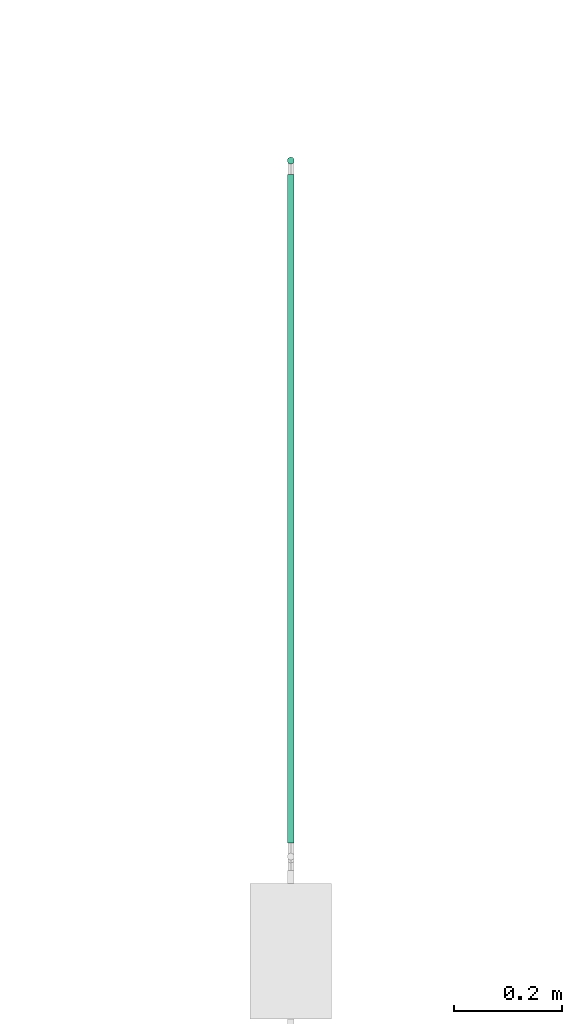
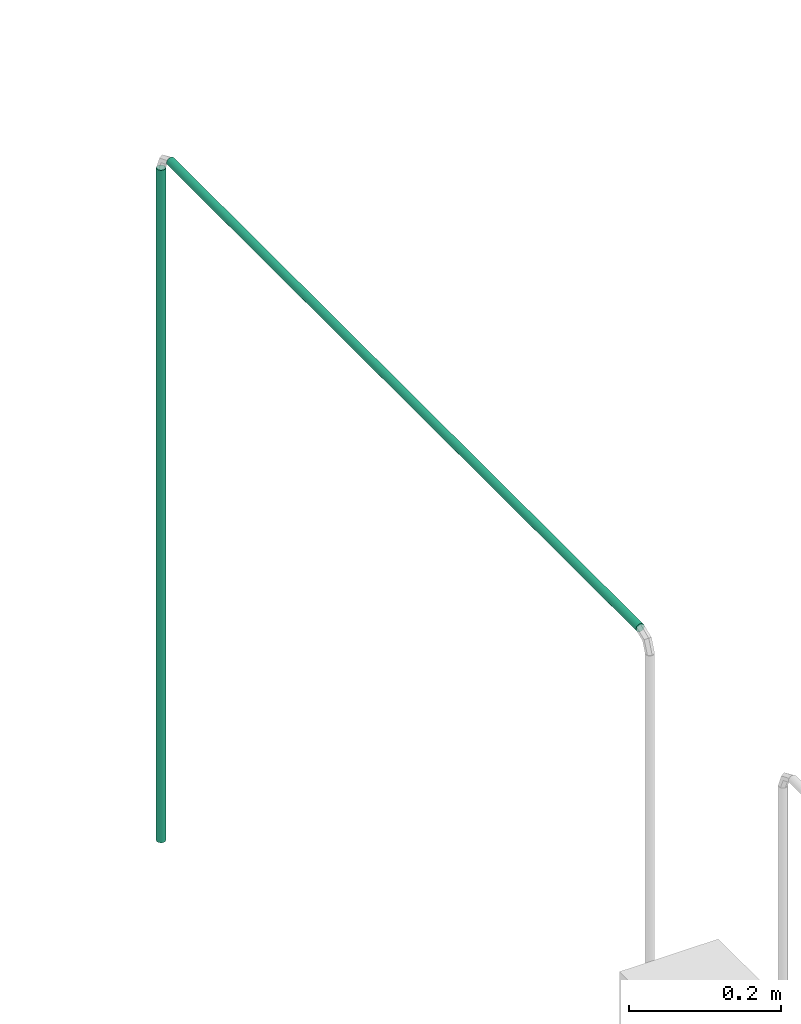
# One storey, part 4 of 45: 2 flow segments.
"""IFC2X3 building model written with IfcOpenShell, lengths in millimetres."""

from ifc_helpers import new_model, entity, si_unit, converted_unit, derived_unit, direction, frame, origin, origin_2d_with_axis, place, context, subcontext, project, spatial, circle, extrude, type_object, element, save


model = new_model("IFC2X3")

# Units and contexts
model_context = context("Model", 3, precision=0.01, world=origin(), true_north=direction((6.12303176911189e-17, 1.0)))
body_context = subcontext(model_context, "Body", "Model", "MODEL_VIEW")
ifc_project = project(units=[si_unit("LENGTHUNIT", "METRE", prefix="MILLI"), si_unit("AREAUNIT", "SQUARE_METRE"), si_unit("VOLUMEUNIT", "CUBIC_METRE"), converted_unit("PLANEANGLEUNIT", "DEGREE", entity("IfcRatioMeasure", 0.0174532925199433), si_unit("PLANEANGLEUNIT", "RADIAN"), dimensions=[0, 0, 0, 0, 0, 0, 0]), si_unit("MASSUNIT", "GRAM", prefix="KILO"), derived_unit("MASSDENSITYUNIT", [(si_unit("MASSUNIT", "GRAM", prefix="KILO"), 1), (si_unit("LENGTHUNIT", "METRE"), -3)]), derived_unit("MOMENTOFINERTIAUNIT", [(si_unit("LENGTHUNIT", "METRE"), 4)]), si_unit("TIMEUNIT", "SECOND"), si_unit("FREQUENCYUNIT", "HERTZ"), si_unit("THERMODYNAMICTEMPERATUREUNIT", "DEGREE_CELSIUS"), derived_unit("THERMALTRANSMITTANCEUNIT", [(si_unit("MASSUNIT", "GRAM", prefix="KILO"), 1), (si_unit("THERMODYNAMICTEMPERATUREUNIT", "KELVIN"), -1), (si_unit("TIMEUNIT", "SECOND"), -3)]), derived_unit("VOLUMETRICFLOWRATEUNIT", [(si_unit("LENGTHUNIT", "METRE"), 3), (si_unit("TIMEUNIT", "SECOND"), -1)]), derived_unit("MASSFLOWRATEUNIT", [(si_unit("MASSUNIT", "GRAM", prefix="KILO"), 1), (si_unit("TIMEUNIT", "SECOND"), -1)]), derived_unit("ROTATIONALFREQUENCYUNIT", [(si_unit("TIMEUNIT", "SECOND"), -1)]), si_unit("ELECTRICCURRENTUNIT", "AMPERE"), si_unit("ELECTRICVOLTAGEUNIT", "VOLT"), si_unit("POWERUNIT", "WATT"), si_unit("FORCEUNIT", "NEWTON", prefix="KILO"), si_unit("ILLUMINANCEUNIT", "LUX"), si_unit("LUMINOUSFLUXUNIT", "LUMEN"), si_unit("LUMINOUSINTENSITYUNIT", "CANDELA"), derived_unit("USERDEFINED", [(si_unit("MASSUNIT", "GRAM", prefix="KILO"), -1), (si_unit("LENGTHUNIT", "METRE"), -2), (si_unit("TIMEUNIT", "SECOND"), 3), (si_unit("LUMINOUSFLUXUNIT", "LUMEN"), 1)]), derived_unit("LINEARVELOCITYUNIT", [(si_unit("LENGTHUNIT", "METRE"), 1), (si_unit("TIMEUNIT", "SECOND"), -1)]), si_unit("PRESSUREUNIT", "PASCAL"), derived_unit("USERDEFINED", [(si_unit("LENGTHUNIT", "METRE"), -2), (si_unit("MASSUNIT", "GRAM", prefix="KILO"), 1), (si_unit("TIMEUNIT", "SECOND"), -2)]), derived_unit("LINEARFORCEUNIT", [(si_unit("MASSUNIT", "GRAM", prefix="KILO"), 1), (si_unit("LENGTHUNIT", "METRE"), 1), (si_unit("TIMEUNIT", "SECOND"), -2), (si_unit("LENGTHUNIT", "METRE"), -1)]), derived_unit("PLANARFORCEUNIT", [(si_unit("MASSUNIT", "GRAM", prefix="KILO"), 1), (si_unit("LENGTHUNIT", "METRE"), 1), (si_unit("TIMEUNIT", "SECOND"), -2), (si_unit("LENGTHUNIT", "METRE"), -2)])], contexts=[model_context])

# Site, building, storey
site_placement = place(None, frame((-24836.06, 8968.75, 0.0)))
site = spatial("IfcSite", under=ifc_project, at=site_placement, CompositionType="ELEMENT")
building_placement = place(site_placement, origin())
building = spatial("IfcBuilding", under=site, at=building_placement, CompositionType="ELEMENT")
storey_placement = place(building_placement, frame((0.0, 0.0, -4200.0)))
storey = spatial("IfcBuildingStorey", under=building, at=storey_placement, CompositionType="ELEMENT", Elevation=-4200.0)

# Flow segments
pipe_segment_type = type_object("IfcPipeSegmentType", PredefinedType="NOTDEFINED")
flow_segment_1_placement = place(storey_placement, frame((74862.81, -5966.43, 1095.2)))
element("IfcFlowSegment", 1, at=flow_segment_1_placement, inside=storey, type_object=pipe_segment_type, context=body_context, shape_type="SweptSolid", body=[
    extrude(circle(Radius=6.35, at=origin_2d_with_axis()), frame((7.95, 7.95, 0.0)), (0.0, 0.0, 1.0), 1079.4),
])
flow_segment_2_placement = place(storey_placement, frame((74862.81, -7218.35, 2192.05)))
element("IfcFlowSegment", 2, at=flow_segment_2_placement, inside=storey, type_object=pipe_segment_type, context=body_context, shape_type="SweptSolid", body=[
    extrude(circle(Radius=6.35, at=origin_2d_with_axis()), frame((7.95, 0.0, 7.95), z_axis=(0.0, 1.0, 0.0), x_axis=(-1.0, 0.0, 0.0)), (0.0, 0.0, 1.0), 1234.47024125078),
])

save(model, "model.ifc")
